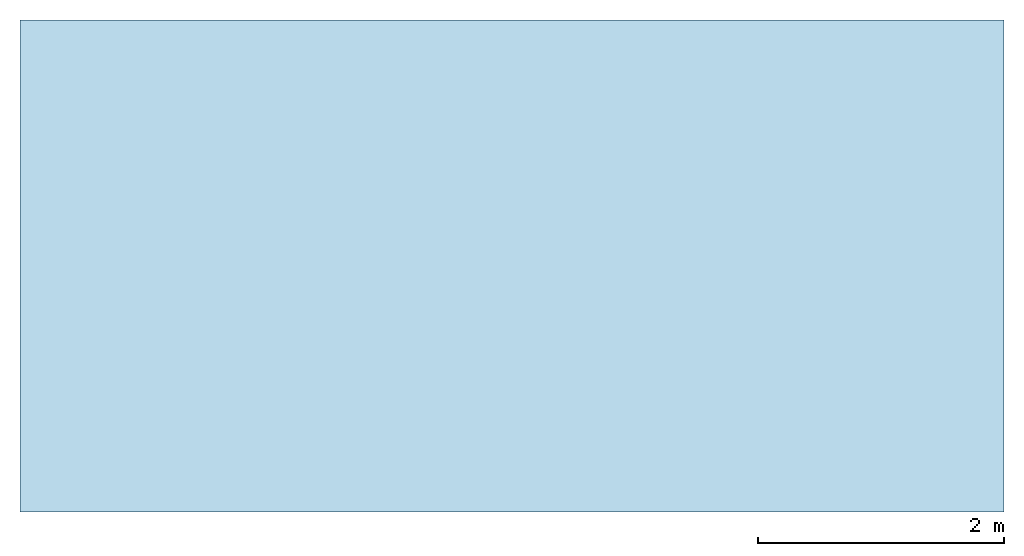
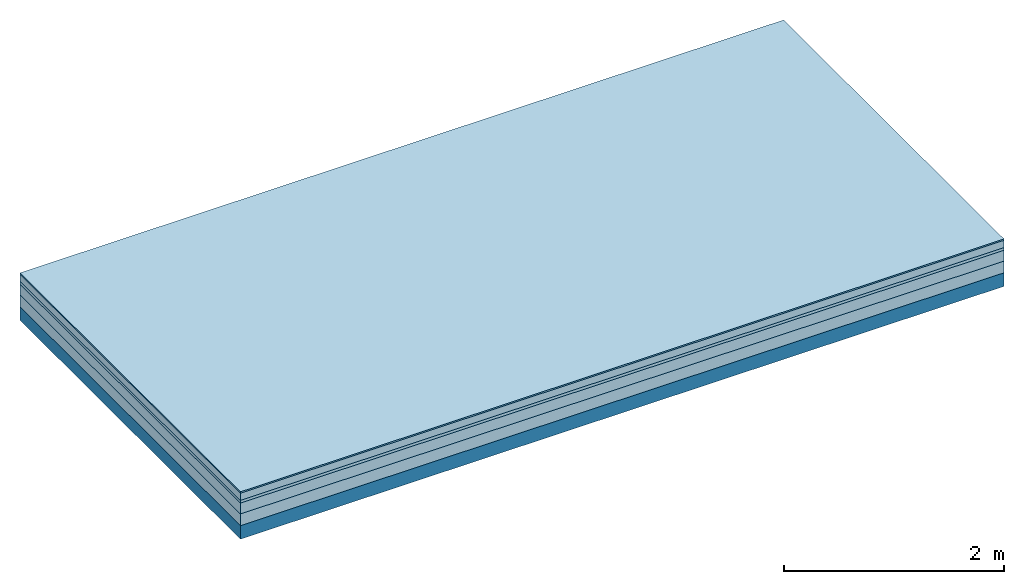
# One storey: 5 plates, 1 member, 1 element without a shape of its own.
"""IFC4 building model written with IfcOpenShell, lengths in metres."""

import ifcopenshell
import ifcopenshell.guid

model = None  # the IFC model being written
_history = None  # IfcOwnerHistory: only IFC2X3 demands one
_inside = {}  # id of a spatial element -> (the spatial element, [elements in it])
_under = {}  # id of a project, library or spatial element -> (it, [spatial elements below it])
_declared = {}  # id of a project -> (the project, [libraries it declares])
_typed = {}  # id of a type object -> (the type object, [elements of that type])
_made_of = {}  # id of a material, layer set ... -> (it, [elements and type objects made of it])


def new_model(schema):
    """Start an empty IFC model of exactly this schema.

    Asked for "IFC4X3", IfcOpenShell would pick the latest addendum, in which some entities
    have other attributes; the version numbers below select the first issue.
    IFC2X3 requires an IfcOwnerHistory on every rooted entity: one is made here for all.
    """
    global model, _history
    if schema == "IFC4X3":
        model = ifcopenshell.file(schema_version=(4, 3, 0, 0))
    else:
        model = ifcopenshell.file(schema=schema)
    _inside.clear()
    _under.clear()
    _declared.clear()
    _typed.clear()
    _made_of.clear()
    _history = None
    if model.schema == "IFC2X3":
        org = make("IfcOrganization", Name="unknown")
        user = make(
            "IfcPersonAndOrganization",
            ThePerson=make("IfcPerson", FamilyName="unknown"),
            TheOrganization=org,
        )
        app = make(
            "IfcApplication",
            ApplicationDeveloper=org,
            Version="unknown",
            ApplicationFullName="unknown",
            ApplicationIdentifier="unknown",
        )
        _history = make(
            "IfcOwnerHistory",
            OwningUser=user,
            OwningApplication=app,
            ChangeAction="ADDED",
            CreationDate=0,
        )
    return model


def make(cls, **values):
    """One entity of the class cls with the attributes given. An attribute that is None is left unset."""
    return model.create_entity(
        cls, **{name: value for name, value in values.items() if value is not None}
    )


def rooted(cls, **values):
    """An entity with a GlobalId (a new one), such as an element, a storey or a relation."""
    return make(cls, GlobalId=ifcopenshell.guid.new(), OwnerHistory=_history, **values)


def si_unit(unit_type, name, prefix=None):
    """IfcSIUnit, for example si_unit("LENGTHUNIT", "METRE", prefix="MILLI")."""
    return make("IfcSIUnit", UnitType=unit_type, Prefix=prefix, Name=name)


def derived_unit(unit_type, elements):
    """IfcDerivedUnit: a product of units, each with its exponent."""
    return make(
        "IfcDerivedUnit",
        Elements=[
            make("IfcDerivedUnitElement", Unit=unit, Exponent=power)
            for unit, power in elements
        ],
        UnitType=unit_type,
    )


def assignment(units):
    """IfcUnitAssignment: the units of a project."""
    return None if units is None else make("IfcUnitAssignment", Units=units)


def point(xyz):
    """IfcCartesianPoint."""
    return None if xyz is None else make("IfcCartesianPoint", Coordinates=xyz)


def direction(xyz):
    """IfcDirection."""
    return None if xyz is None else make("IfcDirection", DirectionRatios=xyz)


def frame(location, z_axis=None, x_axis=None):
    """IfcAxis2Placement3D, a coordinate frame: its origin and axes. An axis left out is left unset."""
    return make(
        "IfcAxis2Placement3D",
        Location=point(location),
        Axis=direction(z_axis),
        RefDirection=direction(x_axis),
    )


def frame_2d(location, x_axis=None):
    """IfcAxis2Placement2D, a coordinate frame in the plane: its origin and x axis."""
    return make(
        "IfcAxis2Placement2D", Location=point(location), RefDirection=direction(x_axis)
    )


def origin():
    """The frame at (0, 0, 0) with its axes left unset."""
    return frame((0.0, 0.0, 0.0))


def origin_with_axes():
    """The frame at (0, 0, 0) with the z axis (0, 0, 1) and the x axis (1, 0, 0) written out."""
    return frame((0.0, 0.0, 0.0), z_axis=(0.0, 0.0, 1.0), x_axis=(1.0, 0.0, 0.0))


def place(relative_to, where):
    """IfcLocalPlacement: puts the frame where relative to a parent placement (None: the world)."""
    return make(
        "IfcLocalPlacement", PlacementRelTo=relative_to, RelativePlacement=where
    )


def context(
    kind, dimensions, precision=None, world=None, true_north=None, identifier=None
):
    """IfcGeometricRepresentationContext, for example the 3D "Model" context."""
    return make(
        "IfcGeometricRepresentationContext",
        ContextIdentifier=identifier,
        ContextType=kind,
        CoordinateSpaceDimension=dimensions,
        Precision=precision,
        WorldCoordinateSystem=world,
        TrueNorth=true_north,
    )


def project(units=None, contexts=None):
    """IfcProject with its units and contexts."""
    return rooted(
        "IfcProject",
        Name="project",
        RepresentationContexts=contexts,
        UnitsInContext=assignment(units),
    )


def spatial(cls, under=None, at=None, **own):
    """A site, building, storey or space (cls), placed at a placement, below another one or the project."""
    s = rooted(cls, ObjectPlacement=at, **own)
    if under is not None:
        _under.setdefault(under.id(), (under, []))[1].append(s)
    return s


def profile(cls, at=None, kind="AREA", **sizes):
    """A parametric profile (cls). Its sizes go by their IFC names, for example OverallWidth=200.0."""
    return make(cls, ProfileType=kind, Position=at, **sizes)


def rectangle(**sizes):
    """IfcRectangleProfileDef."""
    return profile("IfcRectangleProfileDef", **sizes)


def extrude(swept, where, along, depth):
    """IfcExtrudedAreaSolid: the profile swept, set in the frame where, extruded along a direction by depth."""
    return make(
        "IfcExtrudedAreaSolid",
        SweptArea=swept,
        Position=where,
        ExtrudedDirection=direction(along),
        Depth=depth,
    )


def shape(context_of_items, identifier, shape_type, items):
    """IfcShapeRepresentation: the items that make up one representation, for example the "Body"."""
    return make(
        "IfcShapeRepresentation",
        ContextOfItems=context_of_items,
        RepresentationIdentifier=identifier,
        RepresentationType=shape_type,
        Items=items,
    )


def material(Name=None, Category=None):
    """IfcMaterial."""
    return make("IfcMaterial", Name=Name, Category=Category)


def layer(
    of_material, thickness, ventilated=None, Name=None, Category=None, Priority=None
):
    """IfcMaterialLayer: one layer of a wall or slab, of a material (None: an air gap)."""
    return make(
        "IfcMaterialLayer",
        Material=of_material,
        LayerThickness=thickness,
        IsVentilated=ventilated,
        Name=Name,
        Category=Category,
        Priority=Priority,
    )


def layer_set(layers, Name=None):
    """IfcMaterialLayerSet."""
    return make("IfcMaterialLayerSet", MaterialLayers=layers, LayerSetName=Name)


def made_of(thing, what):
    """Note that an element or type object is made of a material, layer set ...; save() writes the relation."""
    if what is not None:
        _made_of.setdefault(what.id(), (what, []))[1].append(thing)
    return thing


def type_object(cls, material=None, **own):
    """A type object (cls), such as IfcWallType, which elements share."""
    return made_of(rooted(cls, **own), material)


def element(
    cls,
    number,
    at=None,
    inside=None,
    cuts=None,
    type_object=None,
    material=None,
    context=None,
    identifier="Body",
    shape_type=None,
    held_by="IfcProductDefinitionShape",
    body=None,
    shapes=None,
    **own,
):
    """One element of the class cls, such as IfcWall. Its Tag is "e" and its number.

    at: its placement. inside: the storey or other place that contains it. cuts: it is an
    opening in that element (IfcRelVoidsElement). A single representation is given by context,
    identifier, shape_type and body (its items); several are given by shapes. held_by: the class
    of the entity that holds the representations. save() writes the other relations.
    """
    e = rooted(cls, Tag="e%d" % number, ObjectPlacement=at, **own)
    if body is not None:
        shapes = [shape(context, identifier, shape_type, body)]
    if shapes is not None:
        e.Representation = make(held_by, Representations=shapes)
    if inside is not None:
        _inside.setdefault(inside.id(), (inside, []))[1].append(e)
    if cuts is not None:
        rooted(
            "IfcRelVoidsElement", RelatingBuildingElement=cuts, RelatedOpeningElement=e
        )
    if type_object is not None:
        _typed.setdefault(type_object.id(), (type_object, []))[1].append(e)
    return made_of(e, material)


def aggregate(whole, parts):
    """IfcRelAggregates: a whole, such as a stair, and the parts it consists of."""
    return rooted("IfcRelAggregates", RelatingObject=whole, RelatedObjects=parts)


def save(model, path):
    """Write the relations noted so far, then the file.

    IfcRelAggregates (storeys below a building ...), IfcRelContainedInSpatialStructure (elements
    in a storey), IfcRelDefinesByType, IfcRelAssociatesMaterial and IfcRelDeclares: one each for
    every whole, place, type object, material and project.
    """
    for whole, parts in _under.values():
        aggregate(whole, parts)
    for where, things in _inside.values():
        rooted(
            "IfcRelContainedInSpatialStructure",
            RelatedElements=things,
            RelatingStructure=where,
        )
    for kind, things in _typed.values():
        rooted("IfcRelDefinesByType", RelatedObjects=things, RelatingType=kind)
    for what, things in _made_of.values():
        rooted("IfcRelAssociatesMaterial", RelatedObjects=things, RelatingMaterial=what)
    for by, libraries in _declared.values():
        rooted("IfcRelDeclares", RelatingContext=by, RelatedDefinitions=libraries)
    model.write(path)


model = new_model("IFC4")

# Units and contexts
plan_context = context("Plan", 3, precision=1e-05, world=origin(), true_north=direction((0.0, 1.0)))
model_context = context("Model", 3, precision=1e-05, world=origin(), true_north=direction((0.0, 1.0)))
ifc_project = project(units=[si_unit("LENGTHUNIT", "METRE"), derived_unit("SOUNDPRESSUREUNIT", [(si_unit("PRESSUREUNIT", "PASCAL", prefix="MICRO"), 0)]), si_unit("ENERGYUNIT", "JOULE", prefix="MEGA"), si_unit("MASSUNIT", "GRAM", prefix="KILO"), derived_unit("THERMALTRANSMITTANCEUNIT", [(si_unit("POWERUNIT", "WATT"), 1), (si_unit("AREAUNIT", "SQUARE_METRE"), -1), (si_unit("THERMODYNAMICTEMPERATUREUNIT", "KELVIN"), -1)]), derived_unit("AREADENSITYUNIT", [(si_unit("MASSUNIT", "GRAM", prefix="KILO"), 1), (si_unit("AREAUNIT", "SQUARE_METRE"), -1)]), derived_unit("USERDEFINED", [(si_unit("ENERGYUNIT", "JOULE", prefix="MEGA"), 1), (si_unit("AREAUNIT", "SQUARE_METRE"), -1)])], contexts=[plan_context, model_context])

# Site, building, storey
site = spatial("IfcSite", under=ifc_project)
building_placement = place(None, origin())
building = spatial("IfcBuilding", under=site, at=building_placement)
storey_placement = place(building_placement, origin())
storey = spatial("IfcBuildingStorey", under=building, at=storey_placement)

# Slab, member, plates
ifc_material_1 = material(Category="11.013")
ifc_layer_1 = layer(ifc_material_1, 0.015, Name="Flooring")
ifc_material_2 = material(Name="Cement screed", Category="04.006")
ifc_layer_2 = layer(ifc_material_2, 0.08, Name="On-material")
ifc_material_3 = material(Name="Wood fiber generic product", Category="10.009")
ifc_layer_3 = layer(ifc_material_3, 0.03, Name="Impact sound insulation")
ifc_material_4 = material(Name="Cement screed with EPS", Category="04.006")
ifc_layer_4 = layer(ifc_material_4, 0.12, Name="on Supporting structure")
ifc_material_5 = material(Category="01.002")
ifc_layer_5 = layer(ifc_material_5, 0.13, Name="Sub-floor")
ifc_material_6 = material(Name="Rigid, of the art")
ifc_layer_6 = layer(ifc_material_6, 0.0, Name="Bond")
ifc_layer_7 = layer(None, 0.15, Name="Supporting structure")
ifc_layer_set = layer_set([ifc_layer_1, ifc_layer_2, ifc_layer_3, ifc_layer_4, ifc_layer_5, ifc_layer_6, ifc_layer_7])
slab_type = type_object("IfcSlabType", Name="A2219", PredefinedType="NOTDEFINED", material=ifc_layer_set)
slab_placement = place(None, frame((0.0, 0.0, 0.0), z_axis=(0.0, 0.0, -1.0), x_axis=(1.0, 0.0, 0.0)))
slab = element("IfcSlab", 1, at=slab_placement, inside=storey, type_object=slab_type, material=ifc_layer_set, Name="Slab #1")
ifc_material_7 = material(Name="Solid timber panel")
member_placement = place(slab_placement, origin())
member = element("IfcMember", 2, at=member_placement, material=ifc_material_7, Name="Supporting structure", context=plan_context, shape_type="SweptSolid", body=[
    extrude(rectangle(XDim=1.0, YDim=0.15, at=frame_2d((0.5, 0.075), x_axis=(1.0, 0.0))), frame((0.0, 4.0, 0.375), z_axis=(0.0, -1.0, 0.0), x_axis=(1.0, 0.0, 0.0)), (0.0, 0.0, 1.0), 4.0),
    extrude(rectangle(XDim=1.0, YDim=0.15, at=frame_2d((0.5, 0.075), x_axis=(1.0, 0.0))), frame((1.0, 4.0, 0.375), z_axis=(0.0, -1.0, 0.0), x_axis=(1.0, 0.0, 0.0)), (0.0, 0.0, 1.0), 4.0),
    extrude(rectangle(XDim=1.0, YDim=0.15, at=frame_2d((0.5, 0.075), x_axis=(1.0, 0.0))), frame((2.0, 4.0, 0.375), z_axis=(0.0, -1.0, 0.0), x_axis=(1.0, 0.0, 0.0)), (0.0, 0.0, 1.0), 4.0),
    extrude(rectangle(XDim=1.0, YDim=0.15, at=frame_2d((0.5, 0.075), x_axis=(1.0, 0.0))), frame((3.0, 4.0, 0.375), z_axis=(0.0, -1.0, 0.0), x_axis=(1.0, 0.0, 0.0)), (0.0, 0.0, 1.0), 4.0),
    extrude(rectangle(XDim=1.0, YDim=0.15, at=frame_2d((0.5, 0.075), x_axis=(1.0, 0.0))), frame((4.0, 4.0, 0.375), z_axis=(0.0, -1.0, 0.0), x_axis=(1.0, 0.0, 0.0)), (0.0, 0.0, 1.0), 4.0),
    extrude(rectangle(XDim=1.0, YDim=0.15, at=frame_2d((0.5, 0.075), x_axis=(1.0, 0.0))), frame((5.0, 4.0, 0.375), z_axis=(0.0, -1.0, 0.0), x_axis=(1.0, 0.0, 0.0)), (0.0, 0.0, 1.0), 4.0),
    extrude(rectangle(XDim=1.0, YDim=0.15, at=frame_2d((0.5, 0.075), x_axis=(1.0, 0.0))), frame((6.0, 4.0, 0.375), z_axis=(0.0, -1.0, 0.0), x_axis=(1.0, 0.0, 0.0)), (0.0, 0.0, 1.0), 4.0),
    extrude(rectangle(XDim=1.0, YDim=0.15, at=frame_2d((0.5, 0.075), x_axis=(1.0, 0.0))), frame((7.0, 4.0, 0.375), z_axis=(0.0, -1.0, 0.0), x_axis=(1.0, 0.0, 0.0)), (0.0, 0.0, 1.0), 4.0),
])
plate_1_placement = place(slab_placement, origin())
plate_1 = element("IfcPlate", 3, at=plate_1_placement, material=ifc_material_1, Name="Flooring", context=plan_context, shape_type="SweptSolid", body=[
    extrude(rectangle(XDim=8.0, YDim=4.0, at=frame_2d((4.0, 2.0), x_axis=(1.0, 0.0))), origin_with_axes(), (0.0, 0.0, 1.0), 0.015),
])
plate_2_placement = place(slab_placement, origin())
plate_2 = element("IfcPlate", 4, at=plate_2_placement, material=ifc_material_2, Name="On-material", context=plan_context, shape_type="SweptSolid", body=[
    extrude(rectangle(XDim=8.0, YDim=4.0, at=frame_2d((4.0, 2.0), x_axis=(1.0, 0.0))), frame((0.0, 0.0, 0.015), z_axis=(0.0, 0.0, 1.0), x_axis=(1.0, 0.0, 0.0)), (0.0, 0.0, 1.0), 0.08),
])
plate_3_placement = place(slab_placement, origin())
plate_3 = element("IfcPlate", 5, at=plate_3_placement, material=ifc_material_3, Name="Impact sound insulation", context=plan_context, shape_type="SweptSolid", body=[
    extrude(rectangle(XDim=8.0, YDim=4.0, at=frame_2d((4.0, 2.0), x_axis=(1.0, 0.0))), frame((0.0, 0.0, 0.095), z_axis=(0.0, 0.0, 1.0), x_axis=(1.0, 0.0, 0.0)), (0.0, 0.0, 1.0), 0.03),
])
plate_4_placement = place(slab_placement, origin())
plate_4 = element("IfcPlate", 6, at=plate_4_placement, material=ifc_material_4, Name="on Supporting structure", context=plan_context, shape_type="SweptSolid", body=[
    extrude(rectangle(XDim=8.0, YDim=4.0, at=frame_2d((4.0, 2.0), x_axis=(1.0, 0.0))), frame((0.0, 0.0, 0.125), z_axis=(0.0, 0.0, 1.0), x_axis=(1.0, 0.0, 0.0)), (0.0, 0.0, 1.0), 0.12),
])
plate_5_placement = place(slab_placement, origin())
plate_5 = element("IfcPlate", 7, at=plate_5_placement, material=ifc_material_5, Name="Sub-floor", context=plan_context, shape_type="SweptSolid", body=[
    extrude(rectangle(XDim=8.0, YDim=4.0, at=frame_2d((4.0, 2.0), x_axis=(1.0, 0.0))), frame((0.0, 0.0, 0.245), z_axis=(0.0, 0.0, 1.0), x_axis=(1.0, 0.0, 0.0)), (0.0, 0.0, 1.0), 0.13),
])
aggregate(slab, [plate_1, plate_2, plate_3, plate_4, plate_5, member])

save(model, "model.ifc")
